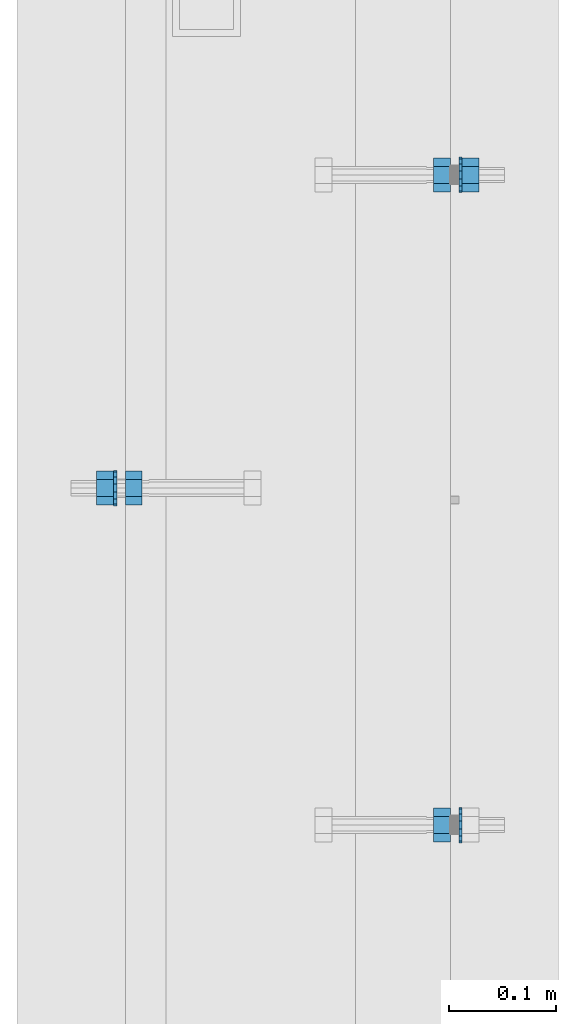
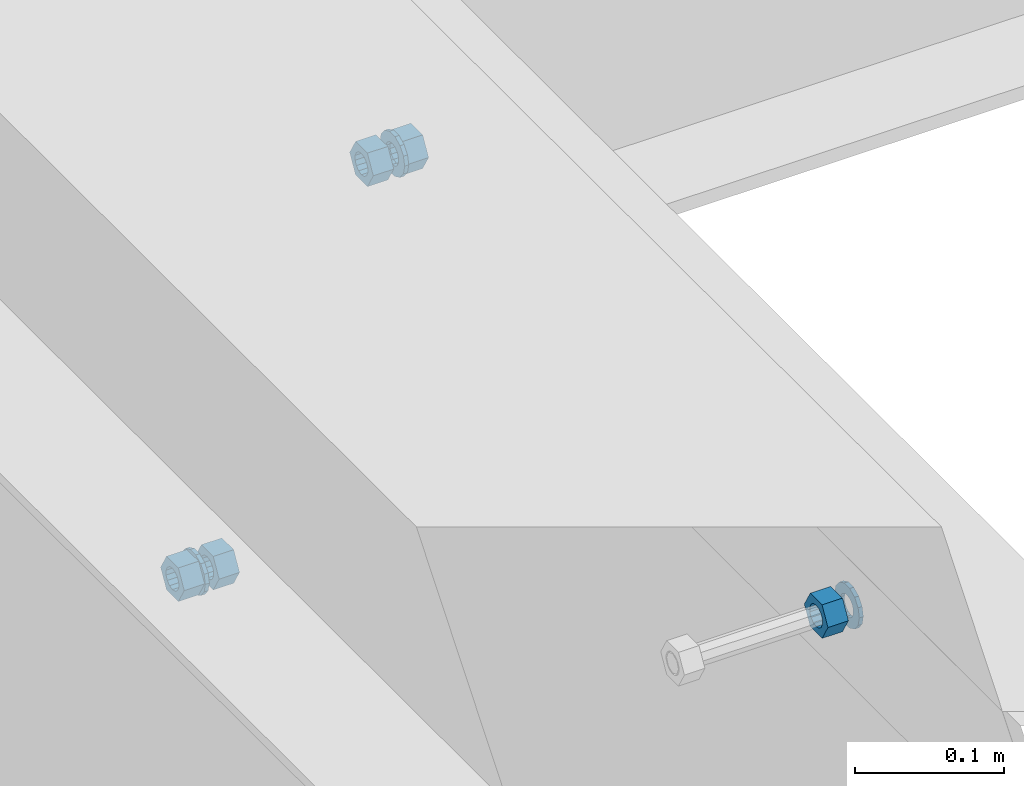
# One storey, part 560 of 975: 8 beams.
"""IFC2X3 building model written with IfcOpenShell, lengths in millimetres."""

from ifc_helpers import new_model, si_unit, frame, origin_with_axes, place, context, subcontext, project, spatial, faceted_brep, material, type_object, element, save


model = new_model("IFC2X3")

# Units and contexts
model_context = context("Model", 3, precision=1e-05, world=origin_with_axes())
body_context = subcontext(model_context, "Body", "Model", "MODEL_VIEW")
ifc_project = project(units=[si_unit("LENGTHUNIT", "METRE", prefix="MILLI"), si_unit("AREAUNIT", "SQUARE_METRE"), si_unit("VOLUMEUNIT", "CUBIC_METRE"), si_unit("MASSUNIT", "GRAM", prefix="KILO"), si_unit("TIMEUNIT", "SECOND"), si_unit("PLANEANGLEUNIT", "RADIAN"), si_unit("SOLIDANGLEUNIT", "STERADIAN"), si_unit("THERMODYNAMICTEMPERATUREUNIT", "DEGREE_CELSIUS"), si_unit("LUMINOUSINTENSITYUNIT", "LUMEN")], contexts=[model_context])

# Site, building, storey
site_placement = place(None, origin_with_axes())
site = spatial("IfcSite", under=ifc_project, at=site_placement, CompositionType="ELEMENT")
building_placement = place(site_placement, origin_with_axes())
building = spatial("IfcBuilding", under=site, at=building_placement, Name="Undefined", CompositionType="ELEMENT")
storey_placement = place(building_placement, origin_with_axes())
storey = spatial("IfcBuildingStorey", under=building, at=storey_placement, Name="Undefined", CompositionType="ELEMENT", Elevation=0.0)

# Beams
ifc_material = material(Name="STEEL/A36")
beam_type_1 = type_object("IfcBeamType", Name="5/8_HEAVY_HEX_NUT", PredefinedType="NOTDEFINED")
beam_1_placement = place(storey_placement, frame((2016.12501801519, 12684.1249755755, 3835.4), z_axis=(0.0, 0.0, 1.0), x_axis=(1.0, 0.0, 0.0)))
element("IfcBeam", 1, at=beam_1_placement, inside=storey, type_object=beam_type_1, material=ifc_material, Name="NUT", ObjectType="5/8_HEAVY_HEX_NUT", context=body_context, shape_type="Brep", body=[
    faceted_brep([(-1.09139364212751e-11, -15.8800001144436, -2.72848410531878e-12), (1.45519152283669e-11, -7.94000005722046, -13.7500000000036), (15.8750000000146, -7.94000005722137, -13.7500000000045), (15.8749999999891, -15.8800001144446, -2.72848410531878e-12), (2.91038304567337e-11, 7.94000005722319, -13.7500000000027), (15.8750000000291, 7.94000005722319, -13.7500000000027), (2.18278728425503e-11, 15.8800001144436, 9.09494701772928e-13), (15.8750000000218, 15.8800001144427, 9.09494701772928e-13), (-7.27595761418343e-12, 7.94000005722046, 13.7500000000027), (15.8749999999927, 7.94000005722046, 13.7500000000027), (-2.18278728425503e-11, -7.94000005722228, 13.7500000000009), (15.8749999999782, -7.94000005722319, 13.7500000000009), (-7.27595761418343e-12, 0.0, 8.72999954223724), (0.0, 3.78780484388062, 7.86545780435881), (15.875, 3.78780484387971, 7.86545780435881), (15.8749999999927, -9.09494701772928e-13, 8.72999954223724), (7.27595761418343e-12, 6.82538848405238, 5.44306568481716), (15.8750000000073, 6.82538848405238, 5.44306568481716), (1.09139364212751e-11, 8.51112022706275, 1.94260765157742), (15.8750000000109, 8.51112022706093, 1.94260765157651), (1.45519152283669e-11, 8.51112022706184, -1.94260765157651), (15.8750000000146, 8.51112022706184, -1.94260765157651), (2.18278728425503e-11, 6.8253884840542, -5.44306568481716), (15.8750000000218, 6.82538848405238, -5.44306568481716), (1.81898940354586e-11, 3.78780484388153, -7.86545780435881), (15.8750000000182, 3.78780484388062, -7.86545780435881), (1.81898940354586e-11, 9.09494701772928e-13, -8.72999954223997), (15.8750000000182, 9.09494701772928e-13, -8.72999954223997), (1.09139364212751e-11, -3.78780484387971, -7.86545780436063), (15.8750000000109, -3.78780484388062, -7.86545780436063), (3.63797880709171e-12, -6.82538848405238, -5.44306568481807), (15.8750000000036, -6.82538848405329, -5.44306568481807), (0.0, -8.51112022706184, -1.94260765157833), (15.875, -8.51112022706184, -1.94260765157833), (-7.27595761418343e-12, -8.51112022706184, 1.9426076515756), (15.8749999999927, -8.51112022706275, 1.9426076515756), (-1.09139364212751e-11, -6.82538848405329, 5.44306568481534), (15.8749999999927, -6.8253884840542, 5.44306568481534), (-7.27595761418343e-12, -3.78780484388062, 7.8654578043579), (15.8749999999927, -3.78780484388153, 7.8654578043579)], [[[0, 1, 2, 3]], [[1, 4, 5, 2]], [[4, 6, 7, 5]], [[6, 8, 9, 7]], [[8, 10, 11, 9]], [[10, 0, 3, 11]], [[12, 13, 14, 15]], [[13, 16, 17, 14]], [[16, 18, 19, 17]], [[18, 20, 21, 19]], [[20, 22, 23, 21]], [[22, 24, 25, 23]], [[24, 26, 27, 25]], [[26, 28, 29, 27]], [[28, 30, 31, 29]], [[30, 32, 33, 31]], [[32, 34, 35, 33]], [[34, 36, 37, 35]], [[36, 38, 39, 37]], [[38, 12, 15, 39]], [[5, 7, 9, 11, 3, 2], [17, 19, 21, 23, 25, 27, 29, 31, 33, 35, 37, 39, 15, 14]], [[10, 8, 6, 4, 1, 0], [38, 36, 34, 32, 30, 28, 26, 24, 22, 20, 18, 16, 13, 12]]]),
])
beam_2_placement = place(storey_placement, frame((2320.92533097779, 12368.2125128106, 3886.2), z_axis=(0.0, 0.0, -1.0), x_axis=(-0.999999999999998, 6.90000001668524e-08, 0.0)))
element("IfcBeam", 2, at=beam_2_placement, inside=storey, type_object=beam_type_1, material=ifc_material, Name="NUT", ObjectType="5/8_HEAVY_HEX_NUT", context=body_context, shape_type="Brep", body=[
    faceted_brep([(-1.09139364212751e-11, -15.8800001144436, -2.72848410531878e-12), (1.45519152283669e-11, -7.94000005722046, -13.7500000000036), (15.8750000000146, -7.94000005722137, -13.7500000000045), (15.8749999999891, -15.8800001144446, -2.72848410531878e-12), (2.91038304567337e-11, 7.94000005722319, -13.7500000000027), (15.8750000000291, 7.94000005722319, -13.7500000000027), (2.18278728425503e-11, 15.8800001144436, 9.09494701772928e-13), (15.8750000000218, 15.8800001144427, 9.09494701772928e-13), (-7.27595761418343e-12, 7.94000005722046, 13.7500000000027), (15.8749999999927, 7.94000005722046, 13.7500000000027), (-2.18278728425503e-11, -7.94000005722228, 13.7500000000009), (15.8749999999782, -7.94000005722319, 13.7500000000009), (-7.27595761418343e-12, 0.0, 8.72999954223724), (0.0, 3.78780484388062, 7.86545780435881), (15.875, 3.78780484387971, 7.86545780435881), (15.8749999999927, -9.09494701772928e-13, 8.72999954223724), (7.27595761418343e-12, 6.82538848405238, 5.44306568481716), (15.8750000000073, 6.82538848405238, 5.44306568481716), (1.09139364212751e-11, 8.51112022706275, 1.94260765157742), (15.8750000000109, 8.51112022706093, 1.94260765157651), (1.45519152283669e-11, 8.51112022706184, -1.94260765157651), (15.8750000000146, 8.51112022706184, -1.94260765157651), (2.18278728425503e-11, 6.8253884840542, -5.44306568481716), (15.8750000000218, 6.82538848405238, -5.44306568481716), (1.81898940354586e-11, 3.78780484388153, -7.86545780435881), (15.8750000000182, 3.78780484388062, -7.86545780435881), (1.81898940354586e-11, 9.09494701772928e-13, -8.72999954223997), (15.8750000000182, 9.09494701772928e-13, -8.72999954223997), (1.09139364212751e-11, -3.78780484387971, -7.86545780436063), (15.8750000000109, -3.78780484388062, -7.86545780436063), (3.63797880709171e-12, -6.82538848405238, -5.44306568481807), (15.8750000000036, -6.82538848405329, -5.44306568481807), (0.0, -8.51112022706184, -1.94260765157833), (15.875, -8.51112022706184, -1.94260765157833), (-7.27595761418343e-12, -8.51112022706184, 1.9426076515756), (15.8749999999927, -8.51112022706275, 1.9426076515756), (-1.09139364212751e-11, -6.82538848405329, 5.44306568481534), (15.8749999999927, -6.8253884840542, 5.44306568481534), (-7.27595761418343e-12, -3.78780484388062, 7.8654578043579), (15.8749999999927, -3.78780484388153, 7.8654578043579)], [[[0, 1, 2, 3]], [[1, 4, 5, 2]], [[4, 6, 7, 5]], [[6, 8, 9, 7]], [[8, 10, 11, 9]], [[10, 0, 3, 11]], [[12, 13, 14, 15]], [[13, 16, 17, 14]], [[16, 18, 19, 17]], [[18, 20, 21, 19]], [[20, 22, 23, 21]], [[22, 24, 25, 23]], [[24, 26, 27, 25]], [[26, 28, 29, 27]], [[28, 30, 31, 29]], [[30, 32, 33, 31]], [[32, 34, 35, 33]], [[34, 36, 37, 35]], [[36, 38, 39, 37]], [[38, 12, 15, 39]], [[5, 7, 9, 11, 3, 2], [17, 19, 21, 23, 25, 27, 29, 31, 33, 35, 37, 39, 15, 14]], [[10, 8, 6, 4, 1, 0], [38, 36, 34, 32, 30, 28, 26, 24, 22, 20, 18, 16, 13, 12]]]),
])
beam_3_placement = place(storey_placement, frame((2320.92525660659, 12977.8125128106, 3886.2), z_axis=(0.0, 0.0, 1.0), x_axis=(-0.999999999999998, 6.90000001668524e-08, 0.0)))
element("IfcBeam", 3, at=beam_3_placement, inside=storey, type_object=beam_type_1, material=ifc_material, Name="NUT", ObjectType="5/8_HEAVY_HEX_NUT", context=body_context, shape_type="Brep", body=[
    faceted_brep([(-1.09139364212751e-11, -15.8800001144436, -2.72848410531878e-12), (1.45519152283669e-11, -7.94000005722046, -13.7500000000036), (15.8750000000146, -7.94000005722137, -13.7500000000045), (15.8749999999891, -15.8800001144446, -2.72848410531878e-12), (2.91038304567337e-11, 7.94000005722319, -13.7500000000027), (15.8750000000291, 7.94000005722319, -13.7500000000027), (2.18278728425503e-11, 15.8800001144436, 9.09494701772928e-13), (15.8750000000218, 15.8800001144427, 9.09494701772928e-13), (-7.27595761418343e-12, 7.94000005722046, 13.7500000000027), (15.8749999999927, 7.94000005722046, 13.7500000000027), (-2.18278728425503e-11, -7.94000005722228, 13.7500000000009), (15.8749999999782, -7.94000005722319, 13.7500000000009), (-7.27595761418343e-12, 0.0, 8.72999954223724), (0.0, 3.78780484388062, 7.86545780435881), (15.875, 3.78780484387971, 7.86545780435881), (15.8749999999927, -9.09494701772928e-13, 8.72999954223724), (7.27595761418343e-12, 6.82538848405238, 5.44306568481716), (15.8750000000073, 6.82538848405238, 5.44306568481716), (1.09139364212751e-11, 8.51112022706275, 1.94260765157742), (15.8750000000109, 8.51112022706093, 1.94260765157651), (1.45519152283669e-11, 8.51112022706184, -1.94260765157651), (15.8750000000146, 8.51112022706184, -1.94260765157651), (2.18278728425503e-11, 6.8253884840542, -5.44306568481716), (15.8750000000218, 6.82538848405238, -5.44306568481716), (1.81898940354586e-11, 3.78780484388153, -7.86545780435881), (15.8750000000182, 3.78780484388062, -7.86545780435881), (1.81898940354586e-11, 9.09494701772928e-13, -8.72999954223997), (15.8750000000182, 9.09494701772928e-13, -8.72999954223997), (1.09139364212751e-11, -3.78780484387971, -7.86545780436063), (15.8750000000109, -3.78780484388062, -7.86545780436063), (3.63797880709171e-12, -6.82538848405238, -5.44306568481807), (15.8750000000036, -6.82538848405329, -5.44306568481807), (0.0, -8.51112022706184, -1.94260765157833), (15.875, -8.51112022706184, -1.94260765157833), (-7.27595761418343e-12, -8.51112022706184, 1.9426076515756), (15.8749999999927, -8.51112022706275, 1.9426076515756), (-1.09139364212751e-11, -6.82538848405329, 5.44306568481534), (15.8749999999927, -6.8253884840542, 5.44306568481534), (-7.27595761418343e-12, -3.78780484388062, 7.8654578043579), (15.8749999999927, -3.78780484388153, 7.8654578043579)], [[[0, 1, 2, 3]], [[1, 4, 5, 2]], [[4, 6, 7, 5]], [[6, 8, 9, 7]], [[8, 10, 11, 9]], [[10, 0, 3, 11]], [[12, 13, 14, 15]], [[13, 16, 17, 14]], [[16, 18, 19, 17]], [[18, 20, 21, 19]], [[20, 22, 23, 21]], [[22, 24, 25, 23]], [[24, 26, 27, 25]], [[26, 28, 29, 27]], [[28, 30, 31, 29]], [[30, 32, 33, 31]], [[32, 34, 35, 33]], [[34, 36, 37, 35]], [[36, 38, 39, 37]], [[38, 12, 15, 39]], [[5, 7, 9, 11, 3, 2], [17, 19, 21, 23, 25, 27, 29, 31, 33, 35, 37, 39, 15, 14]], [[10, 8, 6, 4, 1, 0], [38, 36, 34, 32, 30, 28, 26, 24, 22, 20, 18, 16, 13, 12]]]),
])
beam_4_placement = place(storey_placement, frame((1989.1375167571, 12684.1249757644, 3835.4), z_axis=(0.0, 0.0, 1.0), x_axis=(1.0, 0.0, 0.0)))
element("IfcBeam", 4, at=beam_4_placement, inside=storey, type_object=beam_type_1, material=ifc_material, Name="NUT", ObjectType="5/8_HEAVY_HEX_NUT", context=body_context, shape_type="Brep", body=[
    faceted_brep([(-1.09139364212751e-11, -15.8800001144436, -2.72848410531878e-12), (1.45519152283669e-11, -7.94000005722046, -13.7500000000036), (15.8750000000146, -7.94000005722137, -13.7500000000045), (15.8749999999891, -15.8800001144446, -2.72848410531878e-12), (2.91038304567337e-11, 7.94000005722319, -13.7500000000027), (15.8750000000291, 7.94000005722319, -13.7500000000027), (2.18278728425503e-11, 15.8800001144436, 9.09494701772928e-13), (15.8750000000218, 15.8800001144427, 9.09494701772928e-13), (-7.27595761418343e-12, 7.94000005722046, 13.7500000000027), (15.8749999999927, 7.94000005722046, 13.7500000000027), (-2.18278728425503e-11, -7.94000005722228, 13.7500000000009), (15.8749999999782, -7.94000005722319, 13.7500000000009), (-7.27595761418343e-12, 0.0, 8.72999954223724), (0.0, 3.78780484388062, 7.86545780435881), (15.875, 3.78780484387971, 7.86545780435881), (15.8749999999927, -9.09494701772928e-13, 8.72999954223724), (7.27595761418343e-12, 6.82538848405238, 5.44306568481716), (15.8750000000073, 6.82538848405238, 5.44306568481716), (1.09139364212751e-11, 8.51112022706275, 1.94260765157742), (15.8750000000109, 8.51112022706093, 1.94260765157651), (1.45519152283669e-11, 8.51112022706184, -1.94260765157651), (15.8750000000146, 8.51112022706184, -1.94260765157651), (2.18278728425503e-11, 6.8253884840542, -5.44306568481716), (15.8750000000218, 6.82538848405238, -5.44306568481716), (1.81898940354586e-11, 3.78780484388153, -7.86545780435881), (15.8750000000182, 3.78780484388062, -7.86545780435881), (1.81898940354586e-11, 9.09494701772928e-13, -8.72999954223997), (15.8750000000182, 9.09494701772928e-13, -8.72999954223997), (1.09139364212751e-11, -3.78780484387971, -7.86545780436063), (15.8750000000109, -3.78780484388062, -7.86545780436063), (3.63797880709171e-12, -6.82538848405238, -5.44306568481807), (15.8750000000036, -6.82538848405329, -5.44306568481807), (0.0, -8.51112022706184, -1.94260765157833), (15.875, -8.51112022706184, -1.94260765157833), (-7.27595761418343e-12, -8.51112022706184, 1.9426076515756), (15.8749999999927, -8.51112022706275, 1.9426076515756), (-1.09139364212751e-11, -6.82538848405329, 5.44306568481534), (15.8749999999927, -6.8253884840542, 5.44306568481534), (-7.27595761418343e-12, -3.78780484388062, 7.8654578043579), (15.8749999999927, -3.78780484388153, 7.8654578043579)], [[[0, 1, 2, 3]], [[1, 4, 5, 2]], [[4, 6, 7, 5]], [[6, 8, 9, 7]], [[8, 10, 11, 9]], [[10, 0, 3, 11]], [[12, 13, 14, 15]], [[13, 16, 17, 14]], [[16, 18, 19, 17]], [[18, 20, 21, 19]], [[20, 22, 23, 21]], [[22, 24, 25, 23]], [[24, 26, 27, 25]], [[26, 28, 29, 27]], [[28, 30, 31, 29]], [[30, 32, 33, 31]], [[32, 34, 35, 33]], [[34, 36, 37, 35]], [[36, 38, 39, 37]], [[38, 12, 15, 39]], [[5, 7, 9, 11, 3, 2], [17, 19, 21, 23, 25, 27, 29, 31, 33, 35, 37, 39, 15, 14]], [[10, 8, 6, 4, 1, 0], [38, 36, 34, 32, 30, 28, 26, 24, 22, 20, 18, 16, 13, 12]]]),
])
beam_5_placement = place(storey_placement, frame((2347.91275879817, 12977.8125131154, 3886.2), z_axis=(0.0, 0.0, 1.0), x_axis=(-0.999999999999998, 6.90000001668524e-08, 0.0)))
element("IfcBeam", 5, at=beam_5_placement, inside=storey, type_object=beam_type_1, material=ifc_material, Name="NUT", ObjectType="5/8_HEAVY_HEX_NUT", context=body_context, shape_type="Brep", body=[
    faceted_brep([(-1.09139364212751e-11, -15.8800001144436, -2.72848410531878e-12), (1.45519152283669e-11, -7.94000005722046, -13.7500000000036), (15.8750000000146, -7.94000005722137, -13.7500000000045), (15.8749999999891, -15.8800001144446, -2.72848410531878e-12), (2.91038304567337e-11, 7.94000005722319, -13.7500000000027), (15.8750000000291, 7.94000005722319, -13.7500000000027), (2.18278728425503e-11, 15.8800001144436, 9.09494701772928e-13), (15.8750000000218, 15.8800001144427, 9.09494701772928e-13), (-7.27595761418343e-12, 7.94000005722046, 13.7500000000027), (15.8749999999927, 7.94000005722046, 13.7500000000027), (-2.18278728425503e-11, -7.94000005722228, 13.7500000000009), (15.8749999999782, -7.94000005722319, 13.7500000000009), (-7.27595761418343e-12, 0.0, 8.72999954223724), (0.0, 3.78780484388062, 7.86545780435881), (15.875, 3.78780484387971, 7.86545780435881), (15.8749999999927, -9.09494701772928e-13, 8.72999954223724), (7.27595761418343e-12, 6.82538848405238, 5.44306568481716), (15.8750000000073, 6.82538848405238, 5.44306568481716), (1.09139364212751e-11, 8.51112022706275, 1.94260765157742), (15.8750000000109, 8.51112022706093, 1.94260765157651), (1.45519152283669e-11, 8.51112022706184, -1.94260765157651), (15.8750000000146, 8.51112022706184, -1.94260765157651), (2.18278728425503e-11, 6.8253884840542, -5.44306568481716), (15.8750000000218, 6.82538848405238, -5.44306568481716), (1.81898940354586e-11, 3.78780484388153, -7.86545780435881), (15.8750000000182, 3.78780484388062, -7.86545780435881), (1.81898940354586e-11, 9.09494701772928e-13, -8.72999954223997), (15.8750000000182, 9.09494701772928e-13, -8.72999954223997), (1.09139364212751e-11, -3.78780484387971, -7.86545780436063), (15.8750000000109, -3.78780484388062, -7.86545780436063), (3.63797880709171e-12, -6.82538848405238, -5.44306568481807), (15.8750000000036, -6.82538848405329, -5.44306568481807), (0.0, -8.51112022706184, -1.94260765157833), (15.875, -8.51112022706184, -1.94260765157833), (-7.27595761418343e-12, -8.51112022706184, 1.9426076515756), (15.8749999999927, -8.51112022706275, 1.9426076515756), (-1.09139364212751e-11, -6.82538848405329, 5.44306568481534), (15.8749999999927, -6.8253884840542, 5.44306568481534), (-7.27595761418343e-12, -3.78780484388062, 7.8654578043579), (15.8749999999927, -3.78780484388153, 7.8654578043579)], [[[0, 1, 2, 3]], [[1, 4, 5, 2]], [[4, 6, 7, 5]], [[6, 8, 9, 7]], [[8, 10, 11, 9]], [[10, 0, 3, 11]], [[12, 13, 14, 15]], [[13, 16, 17, 14]], [[16, 18, 19, 17]], [[18, 20, 21, 19]], [[20, 22, 23, 21]], [[22, 24, 25, 23]], [[24, 26, 27, 25]], [[26, 28, 29, 27]], [[28, 30, 31, 29]], [[30, 32, 33, 31]], [[32, 34, 35, 33]], [[34, 36, 37, 35]], [[36, 38, 39, 37]], [[38, 12, 15, 39]], [[5, 7, 9, 11, 3, 2], [17, 19, 21, 23, 25, 27, 29, 31, 33, 35, 37, 39, 15, 14]], [[10, 8, 6, 4, 1, 0], [38, 36, 34, 32, 30, 28, 26, 24, 22, 20, 18, 16, 13, 12]]]),
])
beam_type_2 = type_object("IfcBeamType", Name="5/8_WASHER", PredefinedType="NOTDEFINED")
beam_6_placement = place(storey_placement, frame((2005.0125167571, 12684.1249756533, 3835.4), z_axis=(0.0, 0.0, 1.0), x_axis=(1.0, 0.0, 0.0)))
element("IfcBeam", 6, at=beam_6_placement, inside=storey, type_object=beam_type_2, material=ifc_material, Name="WASHER", ObjectType="5/8_WASHER", context=body_context, shape_type="Brep", body=[
    faceted_brep([(1.09139364212751e-11, -16.670000076293, -2.72848410531878e-12), (2.18278728425503e-11, -15.0191510966704, -7.23284196419536), (3.1750000000211, -15.0191510966711, -7.23284196419627), (3.17500000001019, -16.6700000762937, -1.81898940354586e-12), (2.91038304567337e-11, -10.3935750445523, -13.0331308723944), (3.17500000002838, -10.3935750445526, -13.0331308723953), (2.91038304567337e-11, -3.70942398602756, -16.2520483704566), (3.17500000002838, -3.70942398602779, -16.2520483704566), (2.5465851649642e-11, 3.70942398602961, -16.2520483704557), (3.17500000002474, 3.70942398602961, -16.2520483704566), (1.45519152283669e-11, 10.3935750445542, -13.0331308723935), (3.17500000001382, 10.3935750445537, -13.0331308723944), (0.0, 15.0191510966717, -7.23284196419354), (3.17499999999927, 15.0191510966713, -7.23284196419354), (-7.27595761418343e-12, 16.6700000762933, 0.0), (3.174999999992, 16.6700000762928, -9.09494701772928e-13), (-1.81898940354586e-11, 15.0191510966706, 7.23284196419354), (3.17499999998108, 15.0191510966704, 7.23284196419354), (-2.5465851649642e-11, 10.3935750445519, 13.0331308723926), (3.17499999997381, 10.3935750445517, 13.0331308723926), (-2.5465851649642e-11, 3.70942398602733, 16.2520483704538), (3.17499999997381, 3.7094239860271, 16.2520483704529), (-2.18278728425503e-11, -3.70942398602983, 16.2520483704529), (3.17499999997744, -3.70942398603006, 16.2520483704538), (-1.09139364212751e-11, -10.3935750445542, 13.0331308723908), (3.17499999998836, -10.3935750445544, 13.0331308723908), (0.0, -15.0191510966717, 7.23284196419172), (3.17499999999927, -15.019151096672, 7.23284196419081), (-7.27595761418343e-12, 0.0, 8.72999954223724), (0.0, 3.78780484388062, 7.86545780435881), (3.17499999998472, 3.78780484387903, 7.86545780435699), (3.17499999998836, -9.09494701772928e-13, 8.72999954223542), (7.27595761418343e-12, 6.82538848405238, 5.44306568481716), (3.17499999998836, 6.82538848405102, 5.44306568481534), (1.09139364212751e-11, 8.51112022706275, 1.94260765157742), (3.174999999992, 8.51112022705979, 1.94260765157651), (1.45519152283669e-11, 8.51112022706184, -1.94260765157651), (3.17499999999563, 8.51112022706025, -1.94260765157742), (2.18278728425503e-11, 6.8253884840542, -5.44306568481716), (3.17500000000655, 6.8253884840517, -5.44306568481807), (1.81898940354586e-11, 3.78780484388153, -7.86545780435881), (3.17500000001019, 3.78780484388017, -7.86545780435972), (1.81898940354586e-11, 9.09494701772928e-13, -8.72999954223997), (3.17500000001382, 6.82121026329696e-13, -8.72999954223997), (1.09139364212751e-11, -3.78780484387971, -7.86545780436063), (3.17500000001382, -3.78780484387994, -7.86545780436063), (3.63797880709171e-12, -6.82538848405238, -5.44306568481807), (3.17500000001019, -6.82538848405147, -5.44306568481898), (0.0, -8.51112022706184, -1.94260765157833), (3.17500000001019, -8.5111202270607, -1.94260765157924), (-7.27595761418343e-12, -8.51112022706184, 1.9426076515756), (3.17500000000291, -8.51112022706093, 1.94260765157469), (-1.09139364212751e-11, -6.82538848405329, 5.44306568481534), (3.17499999999563, -6.82538848405238, 5.44306568481534), (-7.27595761418343e-12, -3.78780484388062, 7.8654578043579), (3.174999999992, -3.78780484388085, 7.86545780435699)], [[[0, 1, 2, 3]], [[1, 4, 5, 2]], [[4, 6, 7, 5]], [[6, 8, 9, 7]], [[8, 10, 11, 9]], [[10, 12, 13, 11]], [[12, 14, 15, 13]], [[14, 16, 17, 15]], [[16, 18, 19, 17]], [[18, 20, 21, 19]], [[20, 22, 23, 21]], [[22, 24, 25, 23]], [[24, 26, 27, 25]], [[26, 0, 3, 27]], [[28, 29, 30, 31]], [[29, 32, 33, 30]], [[32, 34, 35, 33]], [[34, 36, 37, 35]], [[36, 38, 39, 37]], [[38, 40, 41, 39]], [[40, 42, 43, 41]], [[42, 44, 45, 43]], [[44, 46, 47, 45]], [[46, 48, 49, 47]], [[48, 50, 51, 49]], [[50, 52, 53, 51]], [[52, 54, 55, 53]], [[54, 28, 31, 55]], [[5, 7, 9, 11, 13, 15, 17, 19, 21, 23, 25, 27, 3, 2], [33, 35, 37, 39, 41, 43, 45, 47, 49, 51, 53, 55, 31, 30]], [[26, 24, 22, 20, 18, 16, 14, 12, 10, 8, 6, 4, 1, 0], [54, 52, 50, 48, 46, 44, 42, 40, 38, 36, 34, 32, 29, 28]]]),
])
beam_7_placement = place(storey_placement, frame((2332.03775879817, 12977.8125131154, 3886.2), z_axis=(0.0, 0.0, 1.0), x_axis=(-0.999999999999998, 6.90000001668524e-08, 0.0)))
element("IfcBeam", 7, at=beam_7_placement, inside=storey, type_object=beam_type_2, material=ifc_material, Name="WASHER", ObjectType="5/8_WASHER", context=body_context, shape_type="Brep", body=[
    faceted_brep([(1.09139364212751e-11, -16.670000076293, -2.72848410531878e-12), (2.18278728425503e-11, -15.0191510966704, -7.23284196419536), (3.1750000000211, -15.0191510966711, -7.23284196419627), (3.17500000001019, -16.6700000762937, -1.81898940354586e-12), (2.91038304567337e-11, -10.3935750445523, -13.0331308723944), (3.17500000002838, -10.3935750445526, -13.0331308723953), (2.91038304567337e-11, -3.70942398602756, -16.2520483704566), (3.17500000002838, -3.70942398602779, -16.2520483704566), (2.5465851649642e-11, 3.70942398602961, -16.2520483704557), (3.17500000002474, 3.70942398602961, -16.2520483704566), (1.45519152283669e-11, 10.3935750445542, -13.0331308723935), (3.17500000001382, 10.3935750445537, -13.0331308723944), (0.0, 15.0191510966717, -7.23284196419354), (3.17499999999927, 15.0191510966713, -7.23284196419354), (-7.27595761418343e-12, 16.6700000762933, 0.0), (3.174999999992, 16.6700000762928, -9.09494701772928e-13), (-1.81898940354586e-11, 15.0191510966706, 7.23284196419354), (3.17499999998108, 15.0191510966704, 7.23284196419354), (-2.5465851649642e-11, 10.3935750445519, 13.0331308723926), (3.17499999997381, 10.3935750445517, 13.0331308723926), (-2.5465851649642e-11, 3.70942398602733, 16.2520483704538), (3.17499999997381, 3.7094239860271, 16.2520483704529), (-2.18278728425503e-11, -3.70942398602983, 16.2520483704529), (3.17499999997744, -3.70942398603006, 16.2520483704538), (-1.09139364212751e-11, -10.3935750445542, 13.0331308723908), (3.17499999998836, -10.3935750445544, 13.0331308723908), (0.0, -15.0191510966717, 7.23284196419172), (3.17499999999927, -15.019151096672, 7.23284196419081), (-7.27595761418343e-12, 0.0, 8.72999954223724), (0.0, 3.78780484388062, 7.86545780435881), (3.17499999998472, 3.78780484387903, 7.86545780435699), (3.17499999998836, -9.09494701772928e-13, 8.72999954223542), (7.27595761418343e-12, 6.82538848405238, 5.44306568481716), (3.17499999998836, 6.82538848405102, 5.44306568481534), (1.09139364212751e-11, 8.51112022706275, 1.94260765157742), (3.174999999992, 8.51112022705979, 1.94260765157651), (1.45519152283669e-11, 8.51112022706184, -1.94260765157651), (3.17499999999563, 8.51112022706025, -1.94260765157742), (2.18278728425503e-11, 6.8253884840542, -5.44306568481716), (3.17500000000655, 6.8253884840517, -5.44306568481807), (1.81898940354586e-11, 3.78780484388153, -7.86545780435881), (3.17500000001019, 3.78780484388017, -7.86545780435972), (1.81898940354586e-11, 9.09494701772928e-13, -8.72999954223997), (3.17500000001382, 6.82121026329696e-13, -8.72999954223997), (1.09139364212751e-11, -3.78780484387971, -7.86545780436063), (3.17500000001382, -3.78780484387994, -7.86545780436063), (3.63797880709171e-12, -6.82538848405238, -5.44306568481807), (3.17500000001019, -6.82538848405147, -5.44306568481898), (0.0, -8.51112022706184, -1.94260765157833), (3.17500000001019, -8.5111202270607, -1.94260765157924), (-7.27595761418343e-12, -8.51112022706184, 1.9426076515756), (3.17500000000291, -8.51112022706093, 1.94260765157469), (-1.09139364212751e-11, -6.82538848405329, 5.44306568481534), (3.17499999999563, -6.82538848405238, 5.44306568481534), (-7.27595761418343e-12, -3.78780484388062, 7.8654578043579), (3.174999999992, -3.78780484388085, 7.86545780435699)], [[[0, 1, 2, 3]], [[1, 4, 5, 2]], [[4, 6, 7, 5]], [[6, 8, 9, 7]], [[8, 10, 11, 9]], [[10, 12, 13, 11]], [[12, 14, 15, 13]], [[14, 16, 17, 15]], [[16, 18, 19, 17]], [[18, 20, 21, 19]], [[20, 22, 23, 21]], [[22, 24, 25, 23]], [[24, 26, 27, 25]], [[26, 0, 3, 27]], [[28, 29, 30, 31]], [[29, 32, 33, 30]], [[32, 34, 35, 33]], [[34, 36, 37, 35]], [[36, 38, 39, 37]], [[38, 40, 41, 39]], [[40, 42, 43, 41]], [[42, 44, 45, 43]], [[44, 46, 47, 45]], [[46, 48, 49, 47]], [[48, 50, 51, 49]], [[50, 52, 53, 51]], [[52, 54, 55, 53]], [[54, 28, 31, 55]], [[5, 7, 9, 11, 13, 15, 17, 19, 21, 23, 25, 27, 3, 2], [33, 35, 37, 39, 41, 43, 45, 47, 49, 51, 53, 55, 31, 30]], [[26, 24, 22, 20, 18, 16, 14, 12, 10, 8, 6, 4, 1, 0], [54, 52, 50, 48, 46, 44, 42, 40, 38, 36, 34, 32, 29, 28]]]),
])
beam_8_placement = place(storey_placement, frame((2332.03790131601, 12368.2125036159, 3886.2), z_axis=(0.0, 0.0, -1.0), x_axis=(-0.999999999999998, 6.90000001668524e-08, 0.0)))
element("IfcBeam", 8, at=beam_8_placement, inside=storey, type_object=beam_type_2, material=ifc_material, Name="WASHER", ObjectType="5/8_WASHER", context=body_context, shape_type="Brep", body=[
    faceted_brep([(1.09139364212751e-11, -16.670000076293, -2.72848410531878e-12), (2.18278728425503e-11, -15.0191510966704, -7.23284196419536), (3.1750000000211, -15.0191510966711, -7.23284196419627), (3.17500000001019, -16.6700000762937, -1.81898940354586e-12), (2.91038304567337e-11, -10.3935750445523, -13.0331308723944), (3.17500000002838, -10.3935750445526, -13.0331308723953), (2.91038304567337e-11, -3.70942398602756, -16.2520483704566), (3.17500000002838, -3.70942398602779, -16.2520483704566), (2.5465851649642e-11, 3.70942398602961, -16.2520483704557), (3.17500000002474, 3.70942398602961, -16.2520483704566), (1.45519152283669e-11, 10.3935750445542, -13.0331308723935), (3.17500000001382, 10.3935750445537, -13.0331308723944), (0.0, 15.0191510966717, -7.23284196419354), (3.17499999999927, 15.0191510966713, -7.23284196419354), (-7.27595761418343e-12, 16.6700000762933, 0.0), (3.174999999992, 16.6700000762928, -9.09494701772928e-13), (-1.81898940354586e-11, 15.0191510966706, 7.23284196419354), (3.17499999998108, 15.0191510966704, 7.23284196419354), (-2.5465851649642e-11, 10.3935750445519, 13.0331308723926), (3.17499999997381, 10.3935750445517, 13.0331308723926), (-2.5465851649642e-11, 3.70942398602733, 16.2520483704538), (3.17499999997381, 3.7094239860271, 16.2520483704529), (-2.18278728425503e-11, -3.70942398602983, 16.2520483704529), (3.17499999997744, -3.70942398603006, 16.2520483704538), (-1.09139364212751e-11, -10.3935750445542, 13.0331308723908), (3.17499999998836, -10.3935750445544, 13.0331308723908), (0.0, -15.0191510966717, 7.23284196419172), (3.17499999999927, -15.019151096672, 7.23284196419081), (-7.27595761418343e-12, 0.0, 8.72999954223724), (0.0, 3.78780484388062, 7.86545780435881), (3.17499999998472, 3.78780484387903, 7.86545780435699), (3.17499999998836, -9.09494701772928e-13, 8.72999954223542), (7.27595761418343e-12, 6.82538848405238, 5.44306568481716), (3.17499999998836, 6.82538848405102, 5.44306568481534), (1.09139364212751e-11, 8.51112022706275, 1.94260765157742), (3.174999999992, 8.51112022705979, 1.94260765157651), (1.45519152283669e-11, 8.51112022706184, -1.94260765157651), (3.17499999999563, 8.51112022706025, -1.94260765157742), (2.18278728425503e-11, 6.8253884840542, -5.44306568481716), (3.17500000000655, 6.8253884840517, -5.44306568481807), (1.81898940354586e-11, 3.78780484388153, -7.86545780435881), (3.17500000001019, 3.78780484388017, -7.86545780435972), (1.81898940354586e-11, 9.09494701772928e-13, -8.72999954223997), (3.17500000001382, 6.82121026329696e-13, -8.72999954223997), (1.09139364212751e-11, -3.78780484387971, -7.86545780436063), (3.17500000001382, -3.78780484387994, -7.86545780436063), (3.63797880709171e-12, -6.82538848405238, -5.44306568481807), (3.17500000001019, -6.82538848405147, -5.44306568481898), (0.0, -8.51112022706184, -1.94260765157833), (3.17500000001019, -8.5111202270607, -1.94260765157924), (-7.27595761418343e-12, -8.51112022706184, 1.9426076515756), (3.17500000000291, -8.51112022706093, 1.94260765157469), (-1.09139364212751e-11, -6.82538848405329, 5.44306568481534), (3.17499999999563, -6.82538848405238, 5.44306568481534), (-7.27595761418343e-12, -3.78780484388062, 7.8654578043579), (3.174999999992, -3.78780484388085, 7.86545780435699)], [[[0, 1, 2, 3]], [[1, 4, 5, 2]], [[4, 6, 7, 5]], [[6, 8, 9, 7]], [[8, 10, 11, 9]], [[10, 12, 13, 11]], [[12, 14, 15, 13]], [[14, 16, 17, 15]], [[16, 18, 19, 17]], [[18, 20, 21, 19]], [[20, 22, 23, 21]], [[22, 24, 25, 23]], [[24, 26, 27, 25]], [[26, 0, 3, 27]], [[28, 29, 30, 31]], [[29, 32, 33, 30]], [[32, 34, 35, 33]], [[34, 36, 37, 35]], [[36, 38, 39, 37]], [[38, 40, 41, 39]], [[40, 42, 43, 41]], [[42, 44, 45, 43]], [[44, 46, 47, 45]], [[46, 48, 49, 47]], [[48, 50, 51, 49]], [[50, 52, 53, 51]], [[52, 54, 55, 53]], [[54, 28, 31, 55]], [[5, 7, 9, 11, 13, 15, 17, 19, 21, 23, 25, 27, 3, 2], [33, 35, 37, 39, 41, 43, 45, 47, 49, 51, 53, 55, 31, 30]], [[26, 24, 22, 20, 18, 16, 14, 12, 10, 8, 6, 4, 1, 0], [54, 52, 50, 48, 46, 44, 42, 40, 38, 36, 34, 32, 29, 28]]]),
])

save(model, "model.ifc")
